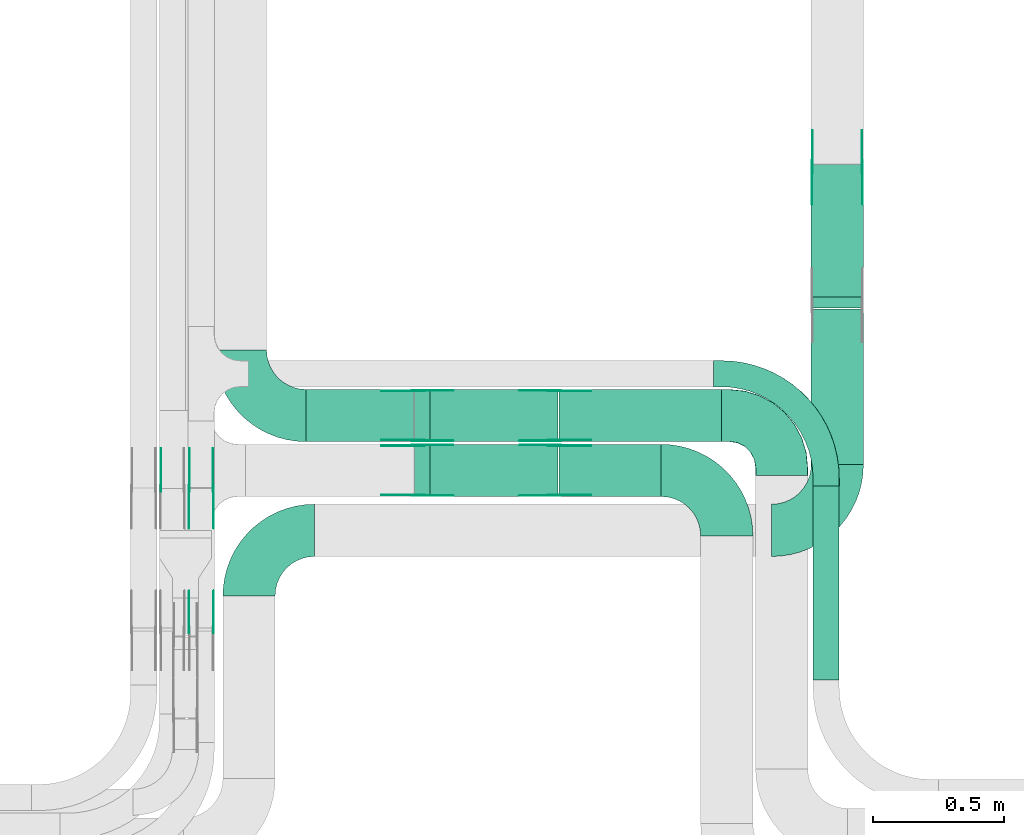
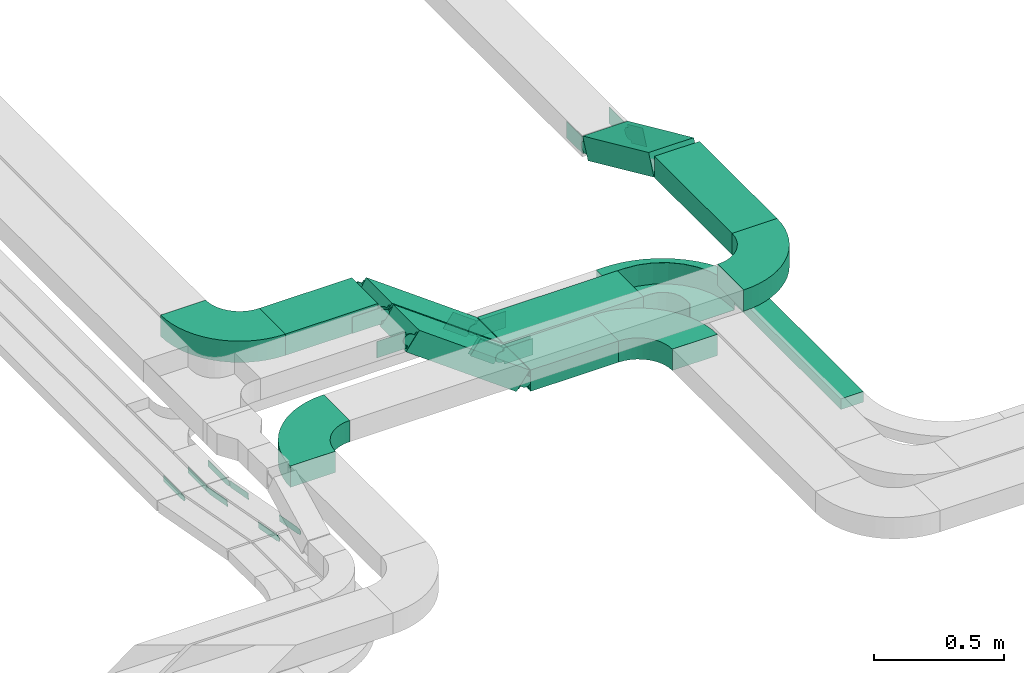
# One storey, part 11 of 23: 33 flow fittings, 8 flow segments.
"""IFC2X3 building model written with IfcOpenShell, lengths in millimetres."""

from ifc_helpers import new_model, entity, si_unit, converted_unit, derived_unit, direction, frame, frame_2d, origin, origin_2d_with_axis, place, context, subcontext, project, spatial, polyline, circle_curve, parameter, trimmed, segment, composite_curve, rectangle, outline, extrude, faceted_brep, source, transform, mapped, material, type_object, type_shapes, element, save


model = new_model("IFC2X3")

# Units and contexts
model_context = context("Model", 3, precision=0.01, world=origin(), true_north=direction((6.12303176911189e-17, 1.0)))
body_context = subcontext(model_context, "Body", "Model", "MODEL_VIEW")
ifc_project = project(units=[si_unit("LENGTHUNIT", "METRE", prefix="MILLI"), si_unit("AREAUNIT", "SQUARE_METRE"), si_unit("VOLUMEUNIT", "CUBIC_METRE"), converted_unit("PLANEANGLEUNIT", "DEGREE", entity("IfcRatioMeasure", 0.0174532925199433), si_unit("PLANEANGLEUNIT", "RADIAN"), dimensions=[0, 0, 0, 0, 0, 0, 0]), si_unit("MASSUNIT", "GRAM", prefix="KILO"), derived_unit("MASSDENSITYUNIT", [(si_unit("MASSUNIT", "GRAM", prefix="KILO"), 1), (si_unit("LENGTHUNIT", "METRE"), -3)]), derived_unit("MOMENTOFINERTIAUNIT", [(si_unit("LENGTHUNIT", "METRE"), 4)]), si_unit("TIMEUNIT", "SECOND"), si_unit("FREQUENCYUNIT", "HERTZ"), si_unit("THERMODYNAMICTEMPERATUREUNIT", "DEGREE_CELSIUS"), derived_unit("THERMALTRANSMITTANCEUNIT", [(si_unit("MASSUNIT", "GRAM", prefix="KILO"), 1), (si_unit("THERMODYNAMICTEMPERATUREUNIT", "KELVIN"), -1), (si_unit("TIMEUNIT", "SECOND"), -3)]), derived_unit("VOLUMETRICFLOWRATEUNIT", [(si_unit("LENGTHUNIT", "METRE"), 3), (si_unit("TIMEUNIT", "SECOND"), -1)]), derived_unit("MASSFLOWRATEUNIT", [(si_unit("MASSUNIT", "GRAM", prefix="KILO"), 1), (si_unit("TIMEUNIT", "SECOND"), -1)]), derived_unit("ROTATIONALFREQUENCYUNIT", [(si_unit("TIMEUNIT", "SECOND"), -1)]), si_unit("ELECTRICCURRENTUNIT", "AMPERE"), si_unit("ELECTRICVOLTAGEUNIT", "VOLT"), si_unit("POWERUNIT", "WATT"), si_unit("FORCEUNIT", "NEWTON", prefix="KILO"), si_unit("ILLUMINANCEUNIT", "LUX"), si_unit("LUMINOUSFLUXUNIT", "LUMEN"), si_unit("LUMINOUSINTENSITYUNIT", "CANDELA"), derived_unit("USERDEFINED", [(si_unit("MASSUNIT", "GRAM", prefix="KILO"), -1), (si_unit("LENGTHUNIT", "METRE"), -2), (si_unit("TIMEUNIT", "SECOND"), 3), (si_unit("LUMINOUSFLUXUNIT", "LUMEN"), 1)]), derived_unit("LINEARVELOCITYUNIT", [(si_unit("LENGTHUNIT", "METRE"), 1), (si_unit("TIMEUNIT", "SECOND"), -1)]), si_unit("PRESSUREUNIT", "PASCAL"), derived_unit("USERDEFINED", [(si_unit("LENGTHUNIT", "METRE"), -2), (si_unit("MASSUNIT", "GRAM", prefix="KILO"), 1), (si_unit("TIMEUNIT", "SECOND"), -2)]), derived_unit("LINEARFORCEUNIT", [(si_unit("MASSUNIT", "GRAM", prefix="KILO"), 1), (si_unit("LENGTHUNIT", "METRE"), 1), (si_unit("TIMEUNIT", "SECOND"), -2), (si_unit("LENGTHUNIT", "METRE"), -1)]), derived_unit("PLANARFORCEUNIT", [(si_unit("MASSUNIT", "GRAM", prefix="KILO"), 1), (si_unit("LENGTHUNIT", "METRE"), 1), (si_unit("TIMEUNIT", "SECOND"), -2), (si_unit("LENGTHUNIT", "METRE"), -2)])], contexts=[model_context])

# Site, building, storey
site_placement = place(None, origin())
site = spatial("IfcSite", under=ifc_project, at=site_placement, CompositionType="ELEMENT")
building_placement = place(site_placement, origin())
building = spatial("IfcBuilding", under=site, at=building_placement, CompositionType="ELEMENT")
storey_placement = place(building_placement, frame((0.0, 0.0, 24000.0)))
storey = spatial("IfcBuildingStorey", under=building, at=storey_placement, CompositionType="ELEMENT", Elevation=24000.0)

# Flow segments
cable_carrier_segment_type = type_object("IfcCableCarrierSegmentType", PredefinedType="CABLETRAYSEGMENT")
flow_segment_1_placement = place(storey_placement, frame((35435.62, 10698.82, 2890.0)))
element("IfcFlowSegment", 1, at=flow_segment_1_placement, inside=storey, type_object=cable_carrier_segment_type, context=body_context, shape_type="SweptSolid", body=[
    extrude(rectangle(XDim=596.343306129946, YDim=199.999999999998, at=origin_2d_with_axis()), frame((100.0, 298.17, 0.0), z_axis=(0.0, 0.0, 1.0), x_axis=(0.0, 1.0, 0.0)), (0.0, 0.0, 1.0), 100.000000000003),
])
flow_segment_2_placement = place(storey_placement, frame((34471.71, 10576.9, 2660.0)))
element("IfcFlowSegment", 2, at=flow_segment_2_placement, inside=storey, type_object=cable_carrier_segment_type, context=body_context, shape_type="SweptSolid", body=[
    extrude(rectangle(XDim=390.371886509737, YDim=199.999999999998, at=origin_2d_with_axis()), frame((195.19, 100.0, 0.0)), (0.0, 0.0, 1.0), 99.9999999999989),
])
flow_segment_3_placement = place(storey_placement, frame((33504.08, 10786.9, 3040.0)))
element("IfcFlowSegment", 3, at=flow_segment_3_placement, inside=storey, type_object=cable_carrier_segment_type, context=body_context, shape_type="SweptSolid", body=[
    extrude(rectangle(XDim=410.371886509728, YDim=200.000000000002, at=origin_2d_with_axis()), frame((205.19, 100.0, 0.0)), (0.0, 0.0, 1.0), 100.000000000003),
])
flow_segment_4_placement = place(storey_placement, frame((34471.71, 10786.9, 2660.0)))
element("IfcFlowSegment", 4, at=flow_segment_4_placement, inside=storey, type_object=cable_carrier_segment_type, context=body_context, shape_type="SweptSolid", body=[
    extrude(rectangle(XDim=621.371886509741, YDim=200.000000000002, at=origin_2d_with_axis()), frame((310.69, 100.0, 0.0)), (0.0, 0.0, 1.0), 100.000000000008),
])
flow_segment_5_placement = place(storey_placement, frame((35443.08, 9874.94, 2660.0)))
element("IfcFlowSegment", 5, at=flow_segment_5_placement, inside=storey, type_object=cable_carrier_segment_type, context=body_context, shape_type="SweptSolid", body=[
    extrude(rectangle(XDim=741.957859858951, YDim=100.000000000003, at=origin_2d_with_axis()), frame((50.0, 370.98, 0.0), z_axis=(0.0, 0.0, 1.0), x_axis=(0.0, -1.0, 0.0)), (0.0, 0.0, 1.0), 49.9999999999973),
])
flow_segment_6_placement = place(storey_placement, frame((35435.62, 11298.73, 2659.67)))
element("IfcFlowSegment", 6, at=flow_segment_6_placement, inside=storey, type_object=cable_carrier_segment_type, context=body_context, shape_type="SweptSolid", body=[
    extrude(rectangle(XDim=100.000000000003, YDim=556.494140571385, at=frame_2d((0.0, 0.0), x_axis=(0.0, 1.0))), frame((0.0, 274.1, 160.33), z_axis=(1.0, 0.0, 0.0), x_axis=(0.0, -0.910954180221993, 0.412507553307909)), (0.0, 0.0, 1.0), 199.999999999998),
])
flow_segment_7_placement = place(storey_placement, frame((33918.62, 10576.9, 2680.62)))
element("IfcFlowSegment", 7, at=flow_segment_7_placement, inside=storey, type_object=cable_carrier_segment_type, context=body_context, shape_type="SweptSolid", body=[
    extrude(rectangle(XDim=100.000000000002, YDim=199.999999999998, at=origin_2d_with_axis()), frame((29.5, 100.0, 398.39), z_axis=(0.807391122257865, 0.0, -0.590016589342356), x_axis=(0.590016589342356, 0.0, 0.807391122257865)), (0.0, 0.0, 1.0), 606.79346054361),
])
flow_segment_8_placement = place(storey_placement, frame((33918.62, 10786.9, 2680.62)))
element("IfcFlowSegment", 8, at=flow_segment_8_placement, inside=storey, type_object=cable_carrier_segment_type, context=body_context, shape_type="SweptSolid", body=[
    extrude(rectangle(XDim=100.000000000002, YDim=200.000000000002, at=origin_2d_with_axis()), frame((29.5, 100.0, 398.39), z_axis=(0.807391122257865, 0.0, -0.590016589342356), x_axis=(0.590016589342356, 0.0, 0.807391122257865)), (0.0, 0.0, 1.0), 606.793460543608),
])

# Flow fittings
ifc_material_1 = material()
cable_carrier_fitting_type_1 = type_object("IfcCableCarrierFittingType", Name="470_DKC_S5_CPO 45 horizontal angle:-", PredefinedType="NOTDEFINED", material=ifc_material_1)
shared_shape_1 = source(origin(), body_context, "Body", "Brep", [
    faceted_brep([(-230.0, -99.2, -49.2), (-230.0, 99.2, -49.2), (-230.0, 99.2, 50.0), (-230.0, 100.0, 50.0), (-230.0, 100.0, -50.0), (-230.0, -100.0, -50.0), (-230.0, -100.0, 50.0), (-230.0, -99.2, 50.0), (-200.0, -100.0, -50.0), (-200.0, -100.0, 50.0), (-141.47, -94.24, 50.0), (-85.19, -77.16, 50.0), (-33.33, -49.44, 50.0), (12.13, -12.13, 50.0), (49.44, 33.33, 50.0), (77.16, 85.19, 50.0), (94.24, 141.47, 50.0), (100.0, 200.0, 50.0), (100.0, 230.0, 50.0), (99.2, 230.0, 50.0), (99.2, 200.0, 50.0), (93.45, 141.63, 50.0), (76.42, 85.5, 50.0), (48.78, 33.77, 50.0), (11.57, -11.57, 50.0), (-33.77, -48.78, 50.0), (-85.5, -76.42, 50.0), (-141.63, -93.45, 50.0), (-200.0, -99.2, 50.0), (-200.0, 99.2, 50.0), (-168.85, 104.13, 50.0), (-140.75, 118.45, 50.0), (-118.45, 140.75, 50.0), (-104.13, 168.85, 50.0), (-99.2, 200.0, 50.0), (-99.2, 230.0, 50.0), (-100.0, 230.0, 50.0), (-100.0, 200.0, 50.0), (-104.89, 169.1, 50.0), (-119.1, 141.22, 50.0), (-141.22, 119.1, 50.0), (-169.1, 104.89, 50.0), (-200.0, 100.0, 50.0), (-200.0, -99.2, -49.2), (-141.63, -93.45, -49.2), (-85.5, -76.42, -49.2), (-33.77, -48.78, -49.2), (11.57, -11.57, -49.2), (48.78, 33.77, -49.2), (76.42, 85.5, -49.2), (93.45, 141.63, -49.2), (99.2, 200.0, -49.2), (99.2, 230.0, -49.2), (-99.2, 230.0, -49.2), (-99.2, 200.0, -49.2), (-104.13, 168.85, -49.2), (-118.45, 140.75, -49.2), (-140.75, 118.45, -49.2), (-168.85, 104.13, -49.2), (-200.0, 99.2, -49.2), (-200.0, 100.0, -50.0), (-141.47, -94.24, -50.0), (-169.1, 104.89, -50.0), (-141.22, 119.1, -50.0), (-119.1, 141.22, -50.0), (-104.89, 169.1, -50.0), (-100.0, 200.0, -50.0), (-100.0, 230.0, -50.0), (100.0, 230.0, -50.0), (100.0, 200.0, -50.0), (94.24, 141.47, -50.0), (77.16, 85.19, -50.0), (49.44, 33.33, -50.0), (12.13, -12.13, -50.0), (-33.33, -49.44, -50.0), (-85.19, -77.16, -50.0)], [[[0, 1, 2, 3, 4, 5, 6, 7]], [[6, 5, 8, 9]], [[7, 6, 9, 10, 11, 12, 13, 14, 15, 16, 17, 18, 19, 20, 21, 22, 23, 24, 25, 26, 27, 28]], [[3, 2, 29, 30, 31, 32, 33, 34, 35, 36, 37, 38, 39, 40, 41, 42]], [[0, 7, 28, 43]], [[1, 0, 43, 44, 45, 46, 47, 48, 49, 50, 51, 52, 53, 54, 55, 56, 57, 58, 59]], [[2, 1, 59, 29]], [[4, 3, 42, 60]], [[61, 8, 5, 4, 60, 62, 63, 64, 65, 66, 67, 68, 69, 70, 71, 72, 73, 74, 75]], [[10, 9, 8, 61]], [[61, 75, 11, 10]], [[74, 12, 11, 75]], [[73, 13, 12, 74]], [[14, 72, 71, 15]], [[15, 71, 70, 16]], [[16, 70, 69, 17]], [[73, 72, 14, 13]], [[44, 43, 28, 27]], [[26, 45, 44, 27]], [[45, 26, 25, 46]], [[25, 24, 47, 46]], [[49, 48, 23, 22]], [[50, 49, 22, 21]], [[51, 50, 21, 20]], [[24, 23, 48, 47]], [[58, 57, 31, 30]], [[59, 58, 30, 29]], [[57, 56, 32, 31]], [[32, 56, 55, 33]], [[33, 55, 54, 34]], [[41, 40, 63, 62]], [[41, 62, 60, 42]], [[40, 39, 64, 63]], [[65, 64, 39, 38]], [[66, 65, 38, 37]], [[67, 36, 35, 53, 52, 19, 18, 68]], [[17, 69, 68, 18]], [[51, 20, 19, 52]], [[34, 54, 53, 35]], [[66, 37, 36, 67]]]),
])
type_shapes(cable_carrier_fitting_type_1, [shared_shape_1])
flow_fitting_1_placement = place(storey_placement, frame((35323.08, 10886.9, 2710.0), z_axis=(0.0, 0.0, 1.0), x_axis=(0.0, 1.0, 0.0)))
element("IfcFlowFitting", 9, at=flow_fitting_1_placement, inside=storey, type_object=cable_carrier_fitting_type_1, material=ifc_material_1, Name="470_DKC_S5_45 horizontal angle", ObjectType="470_DKC_S5_CPO 45 horizontal angle:-", context=body_context, shape_type="MappedRepresentation", body=[
    mapped(shared_shape_1, transform((0.0, 0.0, 0.0), scale=1.0)),
])
cable_carrier_fitting_type_2 = type_object("IfcCableCarrierFittingType", Name="470_DKC_S5_Variable Angle Elbow 0-45:-", PredefinedType="NOTDEFINED", material=ifc_material_1)
shared_shape_2 = source(origin(), body_context, "Body", "SweptSolid", [
    extrude(outline(composite_curve([segment(polyline([(-125.75, -225.25), (-124.75, -225.25)]), True, "CONTINUOUS"), segment(trimmed(circle_curve(frame_2d((-124.75, 124.75), x_axis=(0.0, -1.0)), 350.0), [parameter(0.0)], [parameter(90.0000000000001)], True, "PARAMETER"), True, "CONTINUOUS"), segment(polyline([(225.25, 124.75), (225.25, 125.75)]), True, "CONTINUOUS"), segment(polyline([(225.25, 125.75), (25.25, 125.75)]), True, "CONTINUOUS"), segment(polyline([(25.25, 125.75), (25.25, 124.75)]), True, "CONTINUOUS"), segment(trimmed(circle_curve(frame_2d((-124.75, 124.75), x_axis=(0.0, -1.0)), 150.0), [parameter(0.0)], [parameter(90.0000000000001)], True, "PARAMETER"), False, "CONTINUOUS"), segment(polyline([(-124.75, -25.25), (-125.75, -25.25)]), True, "CONTINUOUS"), segment(polyline([(-125.75, -25.25), (-125.75, -225.25)]), True, "CONTINUOUS")], self_intersect=False)), frame((-125.25, 125.25, -50.0)), (0.0, 0.0, 1.0), 100.0),
])
type_shapes(cable_carrier_fitting_type_2, [shared_shape_2])
flow_fitting_2_placement = place(storey_placement, frame((33285.89, 10447.82, 2940.0), z_axis=(0.0, 0.0, 1.0), x_axis=(-1.0, 0.0, 0.0)))
element("IfcFlowFitting", 10, at=flow_fitting_2_placement, inside=storey, type_object=cable_carrier_fitting_type_2, material=ifc_material_1, Name="470_DKC_S5_Variable Angle Elbow 0-45:-", ObjectType="470_DKC_S5_Variable Angle Elbow 0-45:-", context=body_context, shape_type="MappedRepresentation", body=[
    mapped(shared_shape_2, transform((0.0, 0.0, 0.0), scale=1.0)),
])
flow_fitting_3_placement = place(storey_placement, frame((35535.62, 10447.82, 2940.0)))
element("IfcFlowFitting", 11, at=flow_fitting_3_placement, inside=storey, type_object=cable_carrier_fitting_type_2, material=ifc_material_1, Name="470_DKC_S5_Variable Angle Elbow 0-45:-", ObjectType="470_DKC_S5_Variable Angle Elbow 0-45:-", context=body_context, shape_type="MappedRepresentation", body=[
    mapped(shared_shape_2, transform((0.0, 0.0, 0.0), scale=1.0)),
])
for number, where, z_axis, x_axis, name in (
    (12, (35113.08, 10676.9, 2710.0), (0.0, 0.0, 1.0), (0.0, 1.0, 0.0), "470_DKC_S5_Variable Angle Elbow 0-45:-"),
    (13, (33253.08, 10886.9, 3090.0), (0.0, 0.0, 1.0), (0.0, -1.0, 0.0), "470_DKC_S5_Variable Angle Elbow 0-45:-"),
):
    element("IfcFlowFitting", number, at=place(storey_placement, frame(where, z_axis=z_axis, x_axis=x_axis)), inside=storey, type_object=cable_carrier_fitting_type_2, material=ifc_material_1, Name=name, ObjectType="470_DKC_S5_Variable Angle Elbow 0-45:-", context=body_context, shape_type="MappedRepresentation", body=[
        mapped(shared_shape_2, transform((0.0, 0.0, 0.0), scale=1.0)),
    ])
ifc_material_2 = material(Name="G")
cable_carrier_fitting_type_3 = type_object("IfcCableCarrierFittingType", PredefinedType="NOTDEFINED", material=ifc_material_2)
shared_shape_3 = source(origin(), body_context, "Body", "SweptSolid", [
    extrude(outline(composite_curve([segment(trimmed(circle_curve(frame_2d((-44.59, 0.0), x_axis=(1.0, 0.0)), 12.5), [parameter(90.0000000000007)], [parameter(270.0)], True, "PARAMETER"), True, "CONTINUOUS"), segment(polyline([(-44.59, -12.5), (-33.09, -12.5)]), True, "CONTINUOUS"), segment(polyline([(-33.09, -12.5), (-31.23, -14.5)]), True, "CONTINUOUS"), segment(polyline([(-31.23, -14.5), (108.91, -14.5)]), True, "CONTINUOUS"), segment(polyline([(108.91, -14.5), (108.91, 14.5)]), True, "CONTINUOUS"), segment(polyline([(108.91, 14.5), (-31.23, 14.5)]), True, "CONTINUOUS"), segment(polyline([(-31.23, 14.5), (-33.09, 12.5)]), True, "CONTINUOUS"), segment(polyline([(-33.09, 12.5), (-44.59, 12.5)]), True, "CONTINUOUS")], self_intersect=False)), frame((44.59, 0.0, 0.0), z_axis=(0.0, 0.0, -1.0), x_axis=(1.0, 0.0, 0.0)), (0.0, 0.0, -1.0), 2.0),
])
type_shapes(cable_carrier_fitting_type_3, [shared_shape_3])
for number, where, z_axis, x_axis in (
    (14, (33057.62, 10065.84, 2775.0), (-1.0, 0.0, 0.0), (0.0, 0.983401255749196, -0.181444124156458)),
    (15, (33057.62, 10607.82, 2675.0), (-1.0, 0.0, 0.0), (0.0, -0.983401255749196, 0.181444124156458)),
):
    element("IfcFlowFitting", number, at=place(storey_placement, frame(where, z_axis=z_axis, x_axis=x_axis)), inside=storey, type_object=cable_carrier_fitting_type_3, material=ifc_material_2, context=body_context, shape_type="MappedRepresentation", body=[
        mapped(shared_shape_3, transform((0.0, 0.0, 0.0), scale=1.0)),
    ])
cable_carrier_fitting_type_4 = type_object("IfcCableCarrierFittingType", PredefinedType="NOTDEFINED", material=ifc_material_2)
type_shapes(cable_carrier_fitting_type_4, [shared_shape_3])
flow_fitting_4_placement = place(storey_placement, frame((33146.54, 10607.82, 2675.0), z_axis=(1.0, 0.0, 0.0), x_axis=(0.0, 1.0, 0.0)))
element("IfcFlowFitting", 16, at=flow_fitting_4_placement, inside=storey, type_object=cable_carrier_fitting_type_4, material=ifc_material_2, context=body_context, shape_type="MappedRepresentation", body=[
    mapped(shared_shape_3, transform((0.0, 0.0, 0.0), scale=1.0)),
])
cable_carrier_fitting_type_5 = type_object("IfcCableCarrierFittingType", PredefinedType="NOTDEFINED", material=ifc_material_2)
shared_shape_4 = source(origin(), body_context, "Body", "SweptSolid", [
    extrude(outline(composite_curve([segment(trimmed(circle_curve(frame_2d((-44.59, 0.0), x_axis=(1.0, 0.0)), 12.5), [parameter(90.0000000000007)], [parameter(270.0)], True, "PARAMETER"), True, "CONTINUOUS"), segment(polyline([(-44.59, -12.5), (-33.09, -12.5)]), True, "CONTINUOUS"), segment(polyline([(-33.09, -12.5), (-31.23, -14.5)]), True, "CONTINUOUS"), segment(polyline([(-31.23, -14.5), (108.91, -14.5)]), True, "CONTINUOUS"), segment(polyline([(108.91, -14.5), (108.91, 14.5)]), True, "CONTINUOUS"), segment(polyline([(108.91, 14.5), (-31.23, 14.5)]), True, "CONTINUOUS"), segment(polyline([(-31.23, 14.5), (-33.09, 12.5)]), True, "CONTINUOUS"), segment(polyline([(-33.09, 12.5), (-44.59, 12.5)]), True, "CONTINUOUS")], self_intersect=False)), frame((44.59, 0.0, 0.0)), (0.0, 0.0, 1.0), 2.0),
])
type_shapes(cable_carrier_fitting_type_5, [shared_shape_4])
flow_fitting_5_placement = place(storey_placement, frame((32949.62, 10607.82, 2675.0), z_axis=(-1.0, 0.0, 0.0), x_axis=(0.0, 1.0, 0.0)))
element("IfcFlowFitting", 17, at=flow_fitting_5_placement, inside=storey, type_object=cable_carrier_fitting_type_5, material=ifc_material_2, context=body_context, shape_type="MappedRepresentation", body=[
    mapped(shared_shape_4, transform((0.0, 0.0, 0.0), scale=1.0)),
])
cable_carrier_fitting_type_6 = type_object("IfcCableCarrierFittingType", PredefinedType="NOTDEFINED", material=ifc_material_2)
type_shapes(cable_carrier_fitting_type_6, [shared_shape_4])
for number, where, z_axis, x_axis in (
    (18, (33148.54, 10065.84, 2775.0), (1.0, 0.0, 0.0), (0.0, 0.983401255749196, -0.181444124156458)),
    (19, (33148.54, 10607.82, 2675.0), (1.0, 0.0, 0.0), (0.0, -0.983401255749196, 0.181444124156458)),
):
    element("IfcFlowFitting", number, at=place(storey_placement, frame(where, z_axis=z_axis, x_axis=x_axis)), inside=storey, type_object=cable_carrier_fitting_type_6, material=ifc_material_2, context=body_context, shape_type="MappedRepresentation", body=[
        mapped(shared_shape_4, transform((0.0, 0.0, 0.0), scale=1.0)),
    ])
flow_fitting_6_placement = place(storey_placement, frame((33059.62, 10607.82, 2675.0), z_axis=(-1.0, 0.0, 0.0), x_axis=(0.0, 1.0, 0.0)))
element("IfcFlowFitting", 20, at=flow_fitting_6_placement, inside=storey, type_object=cable_carrier_fitting_type_5, material=ifc_material_2, context=body_context, shape_type="MappedRepresentation", body=[
    mapped(shared_shape_4, transform((0.0, 0.0, 0.0), scale=1.0)),
])
cable_carrier_fitting_type_7 = type_object("IfcCableCarrierFittingType", PredefinedType="NOTDEFINED", material=ifc_material_2)
shared_shape_5 = source(origin(), body_context, "Body", "SweptSolid", [
    extrude(outline(composite_curve([segment(trimmed(circle_curve(frame_2d((-41.47, 0.0), x_axis=(1.0, 0.0)), 25.0), [parameter(90.0000000000007)], [parameter(270.0)], True, "PARAMETER"), True, "CONTINUOUS"), segment(polyline([(-41.47, -25.0), (-29.97, -25.0)]), True, "CONTINUOUS"), segment(polyline([(-29.97, -25.0), (-28.1, -38.5)]), True, "CONTINUOUS"), segment(polyline([(-28.1, -38.5), (99.53, -38.5)]), True, "CONTINUOUS"), segment(polyline([(99.53, -38.5), (99.53, 38.5)]), True, "CONTINUOUS"), segment(polyline([(99.53, 38.5), (-28.1, 38.5)]), True, "CONTINUOUS"), segment(polyline([(-28.1, 38.5), (-29.97, 25.0)]), True, "CONTINUOUS"), segment(polyline([(-29.97, 25.0), (-41.47, 25.0)]), True, "CONTINUOUS")], self_intersect=False)), frame((41.47, 0.0, 0.0), z_axis=(0.0, 0.0, -1.0), x_axis=(1.0, 0.0, 0.0)), (0.0, 0.0, -1.0), 2.0),
])
type_shapes(cable_carrier_fitting_type_7, [shared_shape_5])
flow_fitting_7_placement = place(storey_placement, frame((35440.16, 11837.82, 2700.0), z_axis=(-1.0, 0.0, 0.0), x_axis=(0.0, -0.910954180221981, 0.412507553307936)))
element("IfcFlowFitting", 21, at=flow_fitting_7_placement, inside=storey, type_object=cable_carrier_fitting_type_7, material=ifc_material_2, context=body_context, shape_type="MappedRepresentation", body=[
    mapped(shared_shape_5, transform((0.0, 0.0, 0.0), scale=1.0)),
])
cable_carrier_fitting_type_8 = type_object("IfcCableCarrierFittingType", PredefinedType="NOTDEFINED", material=ifc_material_2)
type_shapes(cable_carrier_fitting_type_8, [shared_shape_5])
flow_fitting_8_placement = place(storey_placement, frame((35629.08, 11837.82, 2700.0), z_axis=(1.0, 0.0, 0.0), x_axis=(0.0, 1.0, 0.0)))
element("IfcFlowFitting", 22, at=flow_fitting_8_placement, inside=storey, type_object=cable_carrier_fitting_type_8, material=ifc_material_2, context=body_context, shape_type="MappedRepresentation", body=[
    mapped(shared_shape_5, transform((0.0, 0.0, 0.0), scale=1.0)),
])
flow_fitting_9_placement = place(storey_placement, frame((34453.08, 10772.36, 2710.0), z_axis=(0.0, 1.0, 0.0), x_axis=(-0.807391122257826, 0.0, 0.590016589342409)))
element("IfcFlowFitting", 23, at=flow_fitting_9_placement, inside=storey, type_object=cable_carrier_fitting_type_7, material=ifc_material_2, context=body_context, shape_type="MappedRepresentation", body=[
    mapped(shared_shape_5, transform((0.0, 0.0, 0.0), scale=1.0)),
])
flow_fitting_10_placement = place(storey_placement, frame((34453.08, 10583.44, 2710.0), z_axis=(0.0, -1.0, 0.0), x_axis=(1.0, 0.0, 0.0)))
element("IfcFlowFitting", 24, at=flow_fitting_10_placement, inside=storey, type_object=cable_carrier_fitting_type_8, material=ifc_material_2, context=body_context, shape_type="MappedRepresentation", body=[
    mapped(shared_shape_5, transform((0.0, 0.0, 0.0), scale=1.0)),
])
flow_fitting_11_placement = place(storey_placement, frame((33933.08, 10772.36, 3090.0), z_axis=(0.0, 1.0, 0.0), x_axis=(0.807391122257826, 0.0, -0.590016589342409)))
element("IfcFlowFitting", 25, at=flow_fitting_11_placement, inside=storey, type_object=cable_carrier_fitting_type_7, material=ifc_material_2, context=body_context, shape_type="MappedRepresentation", body=[
    mapped(shared_shape_5, transform((0.0, 0.0, 0.0), scale=1.0)),
])
flow_fitting_12_placement = place(storey_placement, frame((33933.08, 10583.44, 3090.0), z_axis=(0.0, -1.0, 0.0), x_axis=(-1.0, 0.0, 0.0)))
element("IfcFlowFitting", 26, at=flow_fitting_12_placement, inside=storey, type_object=cable_carrier_fitting_type_8, material=ifc_material_2, context=body_context, shape_type="MappedRepresentation", body=[
    mapped(shared_shape_5, transform((0.0, 0.0, 0.0), scale=1.0)),
])
flow_fitting_13_placement = place(storey_placement, frame((34453.08, 10982.36, 2710.0), z_axis=(0.0, 1.0, 0.0), x_axis=(-0.807391122257826, 0.0, 0.590016589342409)))
element("IfcFlowFitting", 27, at=flow_fitting_13_placement, inside=storey, type_object=cable_carrier_fitting_type_7, material=ifc_material_2, context=body_context, shape_type="MappedRepresentation", body=[
    mapped(shared_shape_5, transform((0.0, 0.0, 0.0), scale=1.0)),
])
flow_fitting_14_placement = place(storey_placement, frame((34453.08, 10793.44, 2710.0), z_axis=(0.0, -1.0, 0.0), x_axis=(1.0, 0.0, 0.0)))
element("IfcFlowFitting", 28, at=flow_fitting_14_placement, inside=storey, type_object=cable_carrier_fitting_type_8, material=ifc_material_2, context=body_context, shape_type="MappedRepresentation", body=[
    mapped(shared_shape_5, transform((0.0, 0.0, 0.0), scale=1.0)),
])
flow_fitting_15_placement = place(storey_placement, frame((33933.08, 10982.36, 3090.0), z_axis=(0.0, 1.0, 0.0), x_axis=(0.807391122257826, 0.0, -0.590016589342409)))
element("IfcFlowFitting", 29, at=flow_fitting_15_placement, inside=storey, type_object=cable_carrier_fitting_type_7, material=ifc_material_2, context=body_context, shape_type="MappedRepresentation", body=[
    mapped(shared_shape_5, transform((0.0, 0.0, 0.0), scale=1.0)),
])
flow_fitting_16_placement = place(storey_placement, frame((33933.08, 10793.44, 3090.0), z_axis=(0.0, -1.0, 0.0), x_axis=(-1.0, 0.0, 0.0)))
element("IfcFlowFitting", 30, at=flow_fitting_16_placement, inside=storey, type_object=cable_carrier_fitting_type_8, material=ifc_material_2, context=body_context, shape_type="MappedRepresentation", body=[
    mapped(shared_shape_5, transform((0.0, 0.0, 0.0), scale=1.0)),
])
cable_carrier_fitting_type_9 = type_object("IfcCableCarrierFittingType", PredefinedType="NOTDEFINED", material=ifc_material_2)
shared_shape_6 = source(origin(), body_context, "Body", "SweptSolid", [
    extrude(outline(composite_curve([segment(trimmed(circle_curve(frame_2d((-41.47, 0.0), x_axis=(1.0, 0.0)), 25.0), [parameter(90.0000000000007)], [parameter(270.0)], True, "PARAMETER"), True, "CONTINUOUS"), segment(polyline([(-41.47, -25.0), (-29.97, -25.0)]), True, "CONTINUOUS"), segment(polyline([(-29.97, -25.0), (-28.1, -38.5)]), True, "CONTINUOUS"), segment(polyline([(-28.1, -38.5), (99.53, -38.5)]), True, "CONTINUOUS"), segment(polyline([(99.53, -38.5), (99.53, 38.5)]), True, "CONTINUOUS"), segment(polyline([(99.53, 38.5), (-28.1, 38.5)]), True, "CONTINUOUS"), segment(polyline([(-28.1, 38.5), (-29.97, 25.0)]), True, "CONTINUOUS"), segment(polyline([(-29.97, 25.0), (-41.47, 25.0)]), True, "CONTINUOUS")], self_intersect=False)), frame((41.47, 0.0, 0.0)), (0.0, 0.0, 1.0), 2.0),
])
type_shapes(cable_carrier_fitting_type_9, [shared_shape_6])
flow_fitting_17_placement = place(storey_placement, frame((35631.08, 11837.82, 2700.0), z_axis=(1.0, 0.0, 0.0), x_axis=(0.0, -0.910954180221981, 0.412507553307936)))
element("IfcFlowFitting", 31, at=flow_fitting_17_placement, inside=storey, type_object=cable_carrier_fitting_type_9, material=ifc_material_2, context=body_context, shape_type="MappedRepresentation", body=[
    mapped(shared_shape_6, transform((0.0, 0.0, 0.0), scale=1.0)),
])
cable_carrier_fitting_type_10 = type_object("IfcCableCarrierFittingType", PredefinedType="NOTDEFINED", material=ifc_material_2)
type_shapes(cable_carrier_fitting_type_10, [shared_shape_6])
flow_fitting_18_placement = place(storey_placement, frame((35442.16, 11837.82, 2700.0), z_axis=(-1.0, 0.0, 0.0), x_axis=(0.0, 1.0, 0.0)))
element("IfcFlowFitting", 32, at=flow_fitting_18_placement, inside=storey, type_object=cable_carrier_fitting_type_10, material=ifc_material_2, context=body_context, shape_type="MappedRepresentation", body=[
    mapped(shared_shape_6, transform((0.0, 0.0, 0.0), scale=1.0)),
])
flow_fitting_19_placement = place(storey_placement, frame((34453.08, 10581.44, 2710.0), z_axis=(0.0, -1.0, 0.0), x_axis=(-0.807391122257826, 0.0, 0.590016589342409)))
element("IfcFlowFitting", 33, at=flow_fitting_19_placement, inside=storey, type_object=cable_carrier_fitting_type_9, material=ifc_material_2, context=body_context, shape_type="MappedRepresentation", body=[
    mapped(shared_shape_6, transform((0.0, 0.0, 0.0), scale=1.0)),
])
flow_fitting_20_placement = place(storey_placement, frame((34453.08, 10770.36, 2710.0), z_axis=(0.0, 1.0, 0.0), x_axis=(1.0, 0.0, 0.0)))
element("IfcFlowFitting", 34, at=flow_fitting_20_placement, inside=storey, type_object=cable_carrier_fitting_type_10, material=ifc_material_2, context=body_context, shape_type="MappedRepresentation", body=[
    mapped(shared_shape_6, transform((0.0, 0.0, 0.0), scale=1.0)),
])
flow_fitting_21_placement = place(storey_placement, frame((33933.08, 10581.44, 3090.0), z_axis=(0.0, -1.0, 0.0), x_axis=(0.807391122257826, 0.0, -0.590016589342409)))
element("IfcFlowFitting", 35, at=flow_fitting_21_placement, inside=storey, type_object=cable_carrier_fitting_type_9, material=ifc_material_2, context=body_context, shape_type="MappedRepresentation", body=[
    mapped(shared_shape_6, transform((0.0, 0.0, 0.0), scale=1.0)),
])
flow_fitting_22_placement = place(storey_placement, frame((33933.08, 10770.36, 3090.0), z_axis=(0.0, 1.0, 0.0), x_axis=(-1.0, 0.0, 0.0)))
element("IfcFlowFitting", 36, at=flow_fitting_22_placement, inside=storey, type_object=cable_carrier_fitting_type_10, material=ifc_material_2, context=body_context, shape_type="MappedRepresentation", body=[
    mapped(shared_shape_6, transform((0.0, 0.0, 0.0), scale=1.0)),
])
flow_fitting_23_placement = place(storey_placement, frame((34453.08, 10791.44, 2710.0), z_axis=(0.0, -1.0, 0.0), x_axis=(-0.807391122257826, 0.0, 0.590016589342409)))
element("IfcFlowFitting", 37, at=flow_fitting_23_placement, inside=storey, type_object=cable_carrier_fitting_type_9, material=ifc_material_2, context=body_context, shape_type="MappedRepresentation", body=[
    mapped(shared_shape_6, transform((0.0, 0.0, 0.0), scale=1.0)),
])
flow_fitting_24_placement = place(storey_placement, frame((34453.08, 10980.36, 2710.0), z_axis=(0.0, 1.0, 0.0), x_axis=(1.0, 0.0, 0.0)))
element("IfcFlowFitting", 38, at=flow_fitting_24_placement, inside=storey, type_object=cable_carrier_fitting_type_10, material=ifc_material_2, context=body_context, shape_type="MappedRepresentation", body=[
    mapped(shared_shape_6, transform((0.0, 0.0, 0.0), scale=1.0)),
])
flow_fitting_25_placement = place(storey_placement, frame((33933.08, 10791.44, 3090.0), z_axis=(0.0, -1.0, 0.0), x_axis=(0.807391122257826, 0.0, -0.590016589342409)))
element("IfcFlowFitting", 39, at=flow_fitting_25_placement, inside=storey, type_object=cable_carrier_fitting_type_9, material=ifc_material_2, context=body_context, shape_type="MappedRepresentation", body=[
    mapped(shared_shape_6, transform((0.0, 0.0, 0.0), scale=1.0)),
])
flow_fitting_26_placement = place(storey_placement, frame((33933.08, 10980.36, 3090.0), z_axis=(0.0, 1.0, 0.0), x_axis=(-1.0, 0.0, 0.0)))
element("IfcFlowFitting", 40, at=flow_fitting_26_placement, inside=storey, type_object=cable_carrier_fitting_type_10, material=ifc_material_2, context=body_context, shape_type="MappedRepresentation", body=[
    mapped(shared_shape_6, transform((0.0, 0.0, 0.0), scale=1.0)),
])
cable_carrier_fitting_type_11 = type_object("IfcCableCarrierFittingType", Name="470_DKC_S5_CPO 45 horizontal angle:-", PredefinedType="NOTDEFINED", material=ifc_material_1)
shared_shape_7 = source(origin(), body_context, "Body", "SweptSolid", [
    extrude(outline(composite_curve([segment(polyline([(-222.5, -257.5), (-192.5, -257.5)]), True, "CONTINUOUS"), segment(trimmed(circle_curve(frame_2d((-192.5, 192.5), x_axis=(0.0, -1.0)), 450.0), [parameter(0.0)], [parameter(90.0)], True, "PARAMETER"), True, "CONTINUOUS"), segment(polyline([(257.5, 192.5), (257.5, 222.5)]), True, "CONTINUOUS"), segment(polyline([(257.5, 222.5), (157.5, 222.5)]), True, "CONTINUOUS"), segment(polyline([(157.5, 222.5), (157.5, 192.5)]), True, "CONTINUOUS"), segment(trimmed(circle_curve(frame_2d((-192.5, 192.5), x_axis=(0.0, -1.0)), 350.0), [parameter(0.0)], [parameter(90.0)], True, "PARAMETER"), False, "CONTINUOUS"), segment(polyline([(-192.5, -157.5), (-222.5, -157.5)]), True, "CONTINUOUS"), segment(polyline([(-222.5, -157.5), (-222.5, -257.5)]), True, "CONTINUOUS")], self_intersect=False)), frame((-207.5, 207.5, -25.0)), (0.0, 0.0, 1.0), 50.0000000000002),
])
type_shapes(cable_carrier_fitting_type_11, [shared_shape_7])
flow_fitting_27_placement = place(storey_placement, frame((35493.08, 11046.9, 2685.0), z_axis=(-0.00450630910080412, 0.0, 0.999989846537598), x_axis=(0.0, 1.0, 0.0)))
element("IfcFlowFitting", 41, at=flow_fitting_27_placement, inside=storey, type_object=cable_carrier_fitting_type_11, material=ifc_material_1, Name="470_DKC_S5_45 horizontal angle", ObjectType="470_DKC_S5_CPO 45 horizontal angle:-", context=body_context, shape_type="MappedRepresentation", body=[
    mapped(shared_shape_7, transform((0.0, 0.0, 0.0), scale=1.0)),
])

save(model, "model.ifc")
